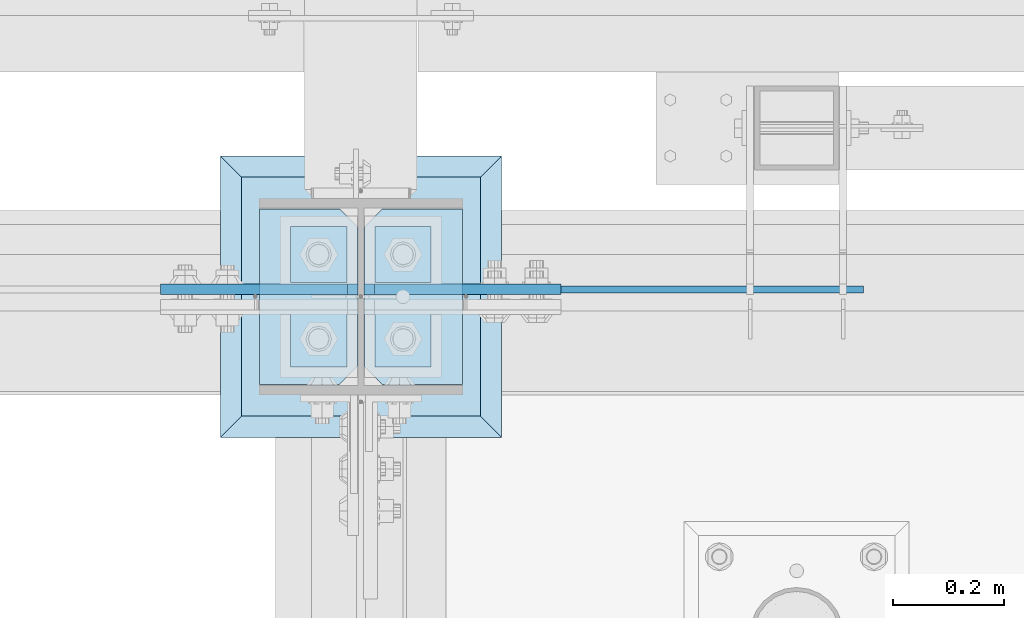
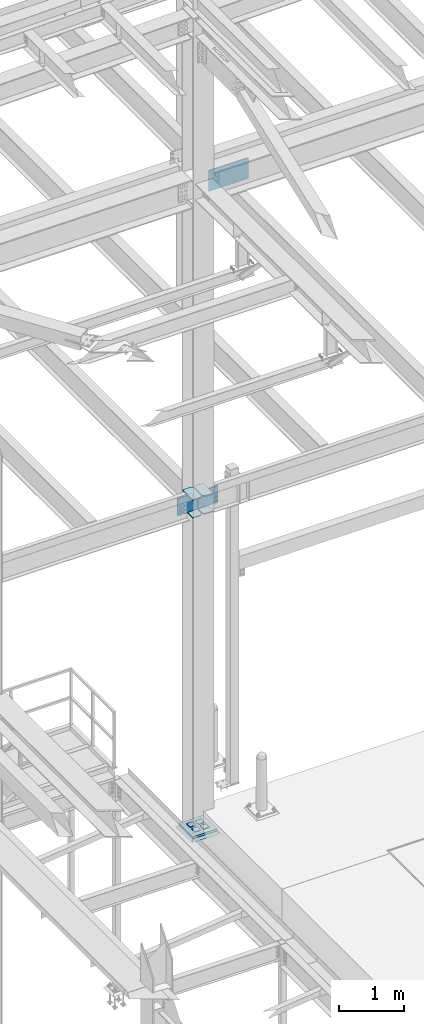
# One storey, part 3428 of 3843: 13 plates, 4 elements without a shape of their own.
"""IFC2X3 building model written with IfcOpenShell, lengths in millimetres."""

from ifc_helpers import new_model, si_unit, frame, origin_with_axes, place, context, subcontext, project, spatial, faceted_brep, material, type_object, element, aggregate, save


model = new_model("IFC2X3")

# Units and contexts
model_context = context("Model", 3, precision=1e-05, world=origin_with_axes())
body_context = subcontext(model_context, "Body", "Model", "MODEL_VIEW")
ifc_project = project(units=[si_unit("LENGTHUNIT", "METRE", prefix="MILLI"), si_unit("AREAUNIT", "SQUARE_METRE"), si_unit("VOLUMEUNIT", "CUBIC_METRE"), si_unit("MASSUNIT", "GRAM", prefix="KILO"), si_unit("TIMEUNIT", "SECOND"), si_unit("PLANEANGLEUNIT", "RADIAN"), si_unit("SOLIDANGLEUNIT", "STERADIAN"), si_unit("THERMODYNAMICTEMPERATUREUNIT", "DEGREE_CELSIUS"), si_unit("LUMINOUSINTENSITYUNIT", "LUMEN")], contexts=[model_context])

# Site, building, storey
site_placement = place(None, origin_with_axes())
site = spatial("IfcSite", under=ifc_project, at=site_placement, CompositionType="ELEMENT")
building_placement = place(site_placement, origin_with_axes())
building = spatial("IfcBuilding", under=site, at=building_placement, Name="Undefined", CompositionType="ELEMENT")
storey_placement = place(building_placement, origin_with_axes())
storey = spatial("IfcBuildingStorey", under=building, at=storey_placement, Name="Undefined", CompositionType="ELEMENT", Elevation=0.0)

# Assembly, plates
assembly_1_placement = place(storey_placement, origin_with_axes())
assembly_1 = element("IfcElementAssembly", 1, at=assembly_1_placement, inside=storey, Name="COLUMN", AssemblyPlace="NOTDEFINED", PredefinedType="RIGID_FRAME")
ifc_material_1 = material(Name="STEEL/A572-50")
plate_type_1 = type_object("IfcPlateType", PredefinedType="NOTDEFINED")
plate_1_placement = place(assembly_1_placement, frame((42245.75625, 92055.95, 36077.525), z_axis=(0.0, 1.0, 0.0), x_axis=(-1.0, 0.0, 0.0)))
plate_1 = element("IfcPlate", 2, at=plate_1_placement, type_object=plate_type_1, material=ifc_material_1, Name="PLATE", context=body_context, shape_type="Brep", body=[
    faceted_brep([(0.0, -9.52500000000146, 0.0), (0.0, -9.52500000000146, 317.5), (0.0, 9.52500000000146, 317.5), (0.0, 9.52500000000146, 0.0), (144.462501525879, -9.52500000000146, 317.5), (144.462501525879, 9.52500000000146, 317.5), (177.800003051758, -9.52500000000146, 284.162498474121), (177.800003051758, 9.52500000000146, 284.162498474121), (177.800003051758, -9.52500000000146, 33.3375015258789), (177.800003051758, 9.52500000000146, 33.3375015258789), (144.462501525879, -9.52500000000146, 0.0), (144.462501525879, 9.52500000000146, 0.0)], [[[0, 1, 2, 3]], [[1, 4, 5, 2]], [[4, 6, 7, 5]], [[6, 8, 9, 7]], [[8, 10, 11, 9]], [[10, 0, 3, 11]], [[5, 7, 9, 11, 3, 2]], [[10, 8, 6, 4, 1, 0]]]),
])
plate_2_placement = place(assembly_1_placement, frame((42245.75625, 92055.95, 36414.075), z_axis=(0.0, 1.0, 0.0), x_axis=(-1.0, 0.0, 0.0)))
plate_2 = element("IfcPlate", 3, at=plate_2_placement, type_object=plate_type_1, material=ifc_material_1, Name="PLATE", context=body_context, shape_type="Brep", body=[
    faceted_brep([(0.0, -9.52500000000146, 0.0), (0.0, -9.52500000000146, 317.5), (0.0, 9.52500000000146, 317.5), (0.0, 9.52500000000146, 0.0), (144.462501525879, -9.52500000000146, 317.5), (144.462501525879, 9.52500000000146, 317.5), (177.800003051758, -9.52500000000146, 284.162498474121), (177.800003051758, 9.52500000000146, 284.162498474121), (177.800003051758, -9.52500000000146, 33.3375015258789), (177.800003051758, 9.52500000000146, 33.3375015258789), (144.462501525879, -9.52500000000146, 0.0), (144.462501525879, 9.52500000000146, 0.0)], [[[0, 1, 2, 3]], [[1, 4, 5, 2]], [[4, 6, 7, 5]], [[6, 8, 9, 7]], [[8, 10, 11, 9]], [[10, 0, 3, 11]], [[5, 7, 9, 11, 3, 2]], [[10, 8, 6, 4, 1, 0]]]),
])
plate_3_placement = place(assembly_1_placement, frame((41879.04375, 92373.45, 36077.525), z_axis=(0.0, -1.0, 0.0), x_axis=(1.0, 0.0, 0.0)))
plate_3 = element("IfcPlate", 4, at=plate_3_placement, type_object=plate_type_1, material=ifc_material_1, Name="PLATE", context=body_context, shape_type="Brep", body=[
    faceted_brep([(0.0, -9.52500000000146, 0.0), (0.0, -9.52500000000146, 317.5), (0.0, 9.52500000000146, 317.5), (0.0, 9.52500000000146, 0.0), (144.462501525879, -9.52500000000146, 317.5), (144.462501525879, 9.52500000000146, 317.5), (177.800003051758, -9.52500000000146, 284.162498474121), (177.800003051758, 9.52500000000146, 284.162498474121), (177.800003051758, -9.52500000000146, 33.3375015258789), (177.800003051758, 9.52500000000146, 33.3375015258789), (144.462501525879, -9.52500000000146, 0.0), (144.462501525879, 9.52500000000146, 0.0)], [[[0, 1, 2, 3]], [[1, 4, 5, 2]], [[4, 6, 7, 5]], [[6, 8, 9, 7]], [[8, 10, 11, 9]], [[10, 0, 3, 11]], [[5, 7, 9, 11, 3, 2]], [[10, 8, 6, 4, 1, 0]]]),
])
plate_4_placement = place(assembly_1_placement, frame((41879.04375, 92373.45, 36414.075), z_axis=(0.0, -1.0, 0.0), x_axis=(1.0, 0.0, 0.0)))
plate_4 = element("IfcPlate", 5, at=plate_4_placement, type_object=plate_type_1, material=ifc_material_1, Name="PLATE", context=body_context, shape_type="Brep", body=[
    faceted_brep([(0.0, -9.52500000000146, 0.0), (0.0, -9.52500000000146, 317.5), (0.0, 9.52500000000146, 317.5), (0.0, 9.52500000000146, 0.0), (144.462501525879, -9.52500000000146, 317.5), (144.462501525879, 9.52500000000146, 317.5), (177.800003051758, -9.52500000000146, 284.162498474121), (177.800003051758, 9.52500000000146, 284.162498474121), (177.800003051758, -9.52500000000146, 33.3375015258789), (177.800003051758, 9.52500000000146, 33.3375015258789), (144.462501525879, -9.52500000000146, 0.0), (144.462501525879, 9.52500000000146, 0.0)], [[[0, 1, 2, 3]], [[1, 4, 5, 2]], [[4, 6, 7, 5]], [[6, 8, 9, 7]], [[8, 10, 11, 9]], [[10, 0, 3, 11]], [[5, 7, 9, 11, 3, 2]], [[10, 8, 6, 4, 1, 0]]]),
])
plate_type_2 = type_object("IfcPlateType", PredefinedType="NOTDEFINED")
plate_5_placement = place(assembly_1_placement, frame((42067.95625, 92228.19375, 36106.1), z_axis=(0.707106781186548, 0.0, 0.707106781186548), x_axis=(0.707106781186548, 0.0, -0.707106781186548)))
plate_5 = element("IfcPlate", 6, at=plate_5_placement, type_object=plate_type_2, material=ifc_material_1, Name="PLATE", context=body_context, shape_type="Brep", body=[
    faceted_brep([(0.0, -9.52500000000146, 0.0), (-197.565634662966, -9.52499999999964, 197.565634662184), (-197.565634662966, 9.52499999999964, 197.565634662184), (0.0, 9.52500000000146, 0.0), (-197.565634662868, -9.52499999999964, 224.506403025414), (-197.565634662868, 9.52499999999964, 224.506403025414), (40.9724185538689, -9.52500000000146, 463.044456243078), (40.9724185538689, 9.52500000000146, 463.044456243078), (265.478821579974, -9.52500000000146, 238.538053217882), (265.478821579974, 9.52500000000146, 238.538053217882), (26.9407683632344, -9.52499999999964, 2.03726813197136e-10), (26.9407683632344, 9.52499999999964, 2.03726813197136e-10)], [[[0, 1, 2, 3]], [[1, 4, 5, 2]], [[4, 6, 7, 5]], [[6, 8, 9, 7]], [[8, 10, 11, 9]], [[10, 0, 3, 11]], [[5, 7, 9, 11, 3, 2]], [[10, 8, 6, 4, 1, 0]]]),
])
plate_6_placement = place(assembly_1_placement, frame((42056.84375, 92228.19375, 36106.1), z_axis=(-0.707106781186548, 0.0, 0.707106781186548), x_axis=(-0.707106781186548, 0.0, -0.707106781186548)))
plate_6 = element("IfcPlate", 7, at=plate_6_placement, type_object=plate_type_2, material=ifc_material_1, Name="PLATE", context=body_context, shape_type="Brep", body=[
    faceted_brep([(0.0, -9.52500000000146, 0.0), (-197.565634662966, -9.52499999999964, 197.565634662184), (-197.565634662966, 9.52499999999964, 197.565634662184), (0.0, 9.52500000000146, 0.0), (-197.565634662868, -9.52499999999964, 224.506403025414), (-197.565634662868, 9.52499999999964, 224.506403025414), (40.9724185538689, -9.52500000000146, 463.044456243078), (40.9724185538689, 9.52500000000146, 463.044456243078), (265.478821579974, -9.52500000000146, 238.538053217882), (265.478821579974, 9.52500000000146, 238.538053217882), (26.9407683632344, -9.52499999999964, 2.03726813197136e-10), (26.9407683632344, 9.52499999999964, 2.03726813197136e-10)], [[[0, 1, 2, 3]], [[1, 4, 5, 2]], [[4, 6, 7, 5]], [[6, 8, 9, 7]], [[8, 10, 11, 9]], [[10, 0, 3, 11]], [[5, 7, 9, 11, 3, 2]], [[10, 8, 6, 4, 1, 0]]]),
])

assembly_2_placement = place(storey_placement, origin_with_axes())
assembly_2 = element("IfcElementAssembly", 8, at=assembly_2_placement, inside=storey, Name="TEMPLATE", AssemblyPlace="NOTDEFINED", PredefinedType="RIGID_FRAME")
plate_type_3 = type_object("IfcPlateType", PredefinedType="NOTDEFINED")
plate_7_placement = place(assembly_2_placement, frame((42037.0, 92189.3, 30105.35), z_axis=(-1.0, 0.0, 0.0), x_axis=(0.0, -1.0, 0.0)))
plate_7 = element("IfcPlate", 9, at=plate_7_placement, type_object=plate_type_3, material=ifc_material_1, Name="Washer Plate", context=body_context, shape_type="Brep", body=[
    faceted_brep([(0.0, -6.3499999046162, 0.0), (-1.67347025126219e-10, -6.35000000000582, 101.600000000151), (-1.67347025126219e-10, 6.35000000000582, 101.600000000151), (7.27595761418343e-12, 6.3499999046162, 0.0), (101.599998474121, -6.34999999999854, 101.599998474121), (101.599998474121, 6.34999999999854, 101.599998474121), (101.6, -6.34999999999854, 0.0), (101.6, 6.34999999999854, 0.0)], [[[0, 1, 2, 3]], [[1, 4, 5, 2]], [[4, 6, 7, 5]], [[6, 0, 3, 7]], [[5, 7, 3, 2]], [[6, 4, 1, 0]]]),
])
plate_8_placement = place(assembly_2_placement, frame((42189.4, 92189.3, 30105.35), z_axis=(-1.0, 0.0, 0.0), x_axis=(0.0, -1.0, 0.0)))
plate_8 = element("IfcPlate", 10, at=plate_8_placement, type_object=plate_type_3, material=ifc_material_1, Name="Washer Plate", context=body_context, shape_type="Brep", body=[
    faceted_brep([(0.0, -6.3499999046162, 0.0), (-1.67347025126219e-10, -6.35000000000582, 101.600000000151), (-1.67347025126219e-10, 6.35000000000582, 101.600000000151), (7.27595761418343e-12, 6.3499999046162, 0.0), (101.599998474121, -6.34999999999854, 101.599998474121), (101.599998474121, 6.34999999999854, 101.599998474121), (101.6, -6.34999999999854, 0.0), (101.6, 6.34999999999854, 0.0)], [[[0, 1, 2, 3]], [[1, 4, 5, 2]], [[4, 6, 7, 5]], [[6, 0, 3, 7]], [[5, 7, 3, 2]], [[6, 4, 1, 0]]]),
])
plate_9_placement = place(assembly_2_placement, frame((42037.0, 92341.7, 30105.35), z_axis=(-1.0, 0.0, 0.0), x_axis=(0.0, -1.0, 0.0)))
plate_9 = element("IfcPlate", 11, at=plate_9_placement, type_object=plate_type_3, material=ifc_material_1, Name="Washer Plate", context=body_context, shape_type="Brep", body=[
    faceted_brep([(0.0, -6.3499999046162, 0.0), (-1.67347025126219e-10, -6.35000000000582, 101.600000000151), (-1.67347025126219e-10, 6.35000000000582, 101.600000000151), (7.27595761418343e-12, 6.3499999046162, 0.0), (101.599998474121, -6.34999999999854, 101.599998474121), (101.599998474121, 6.34999999999854, 101.599998474121), (101.6, -6.34999999999854, 0.0), (101.6, 6.34999999999854, 0.0)], [[[0, 1, 2, 3]], [[1, 4, 5, 2]], [[4, 6, 7, 5]], [[6, 0, 3, 7]], [[5, 7, 3, 2]], [[6, 4, 1, 0]]]),
])
plate_10_placement = place(assembly_2_placement, frame((42189.4, 92341.7, 30105.35), z_axis=(-1.0, 0.0, 0.0), x_axis=(0.0, -1.0, 0.0)))
plate_10 = element("IfcPlate", 12, at=plate_10_placement, type_object=plate_type_3, material=ifc_material_1, Name="Washer Plate", context=body_context, shape_type="Brep", body=[
    faceted_brep([(0.0, -6.3499999046162, 0.0), (-1.67347025126219e-10, -6.35000000000582, 101.600000000151), (-1.67347025126219e-10, 6.35000000000582, 101.600000000151), (7.27595761418343e-12, 6.3499999046162, 0.0), (101.599998474121, -6.34999999999854, 101.599998474121), (101.599998474121, 6.34999999999854, 101.599998474121), (101.6, -6.34999999999854, 0.0), (101.6, 6.34999999999854, 0.0)], [[[0, 1, 2, 3]], [[1, 4, 5, 2]], [[4, 6, 7, 5]], [[6, 0, 3, 7]], [[5, 7, 3, 2]], [[6, 4, 1, 0]]]),
])
aggregate(assembly_2, [plate_7, plate_8, plate_9, plate_10])

# Assembly, plate
assembly_3_placement = place(storey_placement, origin_with_axes())
assembly_3 = element("IfcElementAssembly", 13, at=assembly_3_placement, inside=storey, Name="BEAM", AssemblyPlace="NOTDEFINED", PredefinedType="RIGID_FRAME")
plate_type_4 = type_object("IfcPlateType", PredefinedType="NOTDEFINED")
plate_11_placement = place(assembly_3_placement, frame((42259.2500000001, 92227.4, 42017.949987793), z_axis=(0.0, 0.0, 1.0), x_axis=(1.0, 0.0, 0.0)))
plate_11 = element("IfcPlate", 14, at=plate_11_placement, type_object=plate_type_4, material=ifc_material_1, Name="PLATE", context=body_context, shape_type="Brep", body=[
    faceted_brep([(0.0, -6.3499999046162, 0.0), (0.0, -6.34999999999854, 393.700012207031), (0.0, 6.34999999999854, 393.700012207031), (7.27595761418343e-12, 6.3499999046162, 0.0), (711.199999999968, -6.35000000000582, 393.700012207031), (711.200000000012, 6.34999999999854, 393.700000000004), (711.199999999968, -6.35000000000582, 0.0), (711.199999999997, 6.34999999999854, 0.0)], [[[0, 1, 2, 3]], [[1, 4, 5, 2]], [[4, 6, 7, 5]], [[6, 0, 3, 7]], [[7, 3, 2, 5]], [[6, 4, 1, 0]]]),
])
aggregate(assembly_3, [plate_11])

# Plate
plate_type_5 = type_object("IfcPlateType", PredefinedType="NOTDEFINED")
plate_12_placement = place(assembly_1_placement, frame((41846.5, 92430.6, 30079.95), z_axis=(1.0, 0.0, 0.0), x_axis=(0.0, -1.0, 0.0)))
plate_12 = element("IfcPlate", 15, at=plate_12_placement, type_object=plate_type_5, material=ifc_material_1, Name="PLATE", context=body_context, shape_type="Brep", body=[
    faceted_brep([(0.0, -19.0500000000029, 0.0), (0.0, -19.0499999999993, 431.799987792969), (0.0, 19.0499999999993, 431.799987792969), (0.0, 19.0500000000029, 0.0), (431.799987792969, -19.0499999999993, 431.799987792969), (431.799987792969, 19.0499999999993, 431.799987792969), (431.799957275391, -19.0499999999993, 0.0), (431.799957275391, 19.0499999999993, 0.0)], [[[0, 1, 2, 3]], [[1, 4, 5, 2]], [[4, 6, 7, 5]], [[6, 0, 3, 7]], [[5, 7, 3, 2]], [[6, 4, 1, 0]]]),
])

aggregate(assembly_1, [plate_1, plate_2, plate_5, plate_3, plate_4, plate_6, plate_12])

# Assembly, plate
assembly_4_placement = place(storey_placement, origin_with_axes())
assembly_4 = element("IfcElementAssembly", 16, at=assembly_4_placement, inside=storey, Name="GROUT", AssemblyPlace="NOTDEFINED", PredefinedType="REINFORCEMENT_UNIT")
ifc_material_2 = material(Name="CONCRETE/Concrete_Undefined")
plate_type_6 = type_object("IfcPlateType", PredefinedType="NOTDEFINED")
plate_13_placement = place(assembly_4_placement, frame((41808.4, 92468.7, 30041.85), z_axis=(1.0, 0.0, 0.0), x_axis=(0.0, -1.0, 0.0)))
plate_13 = element("IfcPlate", 17, at=plate_13_placement, type_object=plate_type_6, material=ifc_material_2, Name="GROUT", context=body_context, shape_type="Brep", body=[
    faceted_brep([(38.1000000007043, -19.0499999997883, 469.899999999314), (0.0, 19.0499999999993, 508.0), (0.0, 19.0500000000029, 0.0), (38.1000000006916, -19.0499999999811, 38.1000000006607), (469.899999999325, -19.0499999998174, 38.1000000006607), (508.0, 19.0499999999993, 0.0), (508.0, 19.0499999999993, 508.0), (469.899999999325, -19.0499999999847, 469.899999999314)], [[[0, 1, 2, 3]], [[4, 5, 6, 7]], [[4, 7, 0, 3]], [[5, 4, 3, 2]], [[6, 5, 2, 1]], [[7, 6, 1, 0]]]),
])
aggregate(assembly_4, [plate_13])

save(model, "model.ifc")
